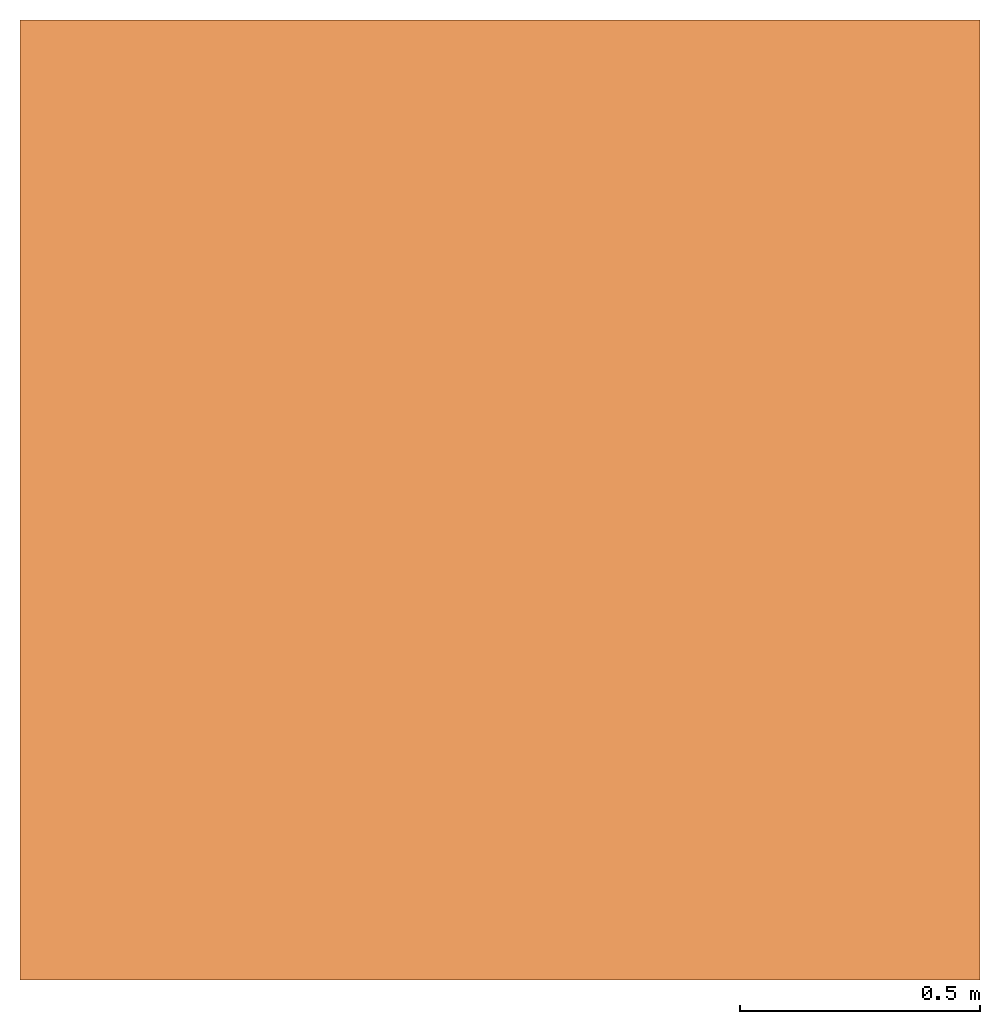
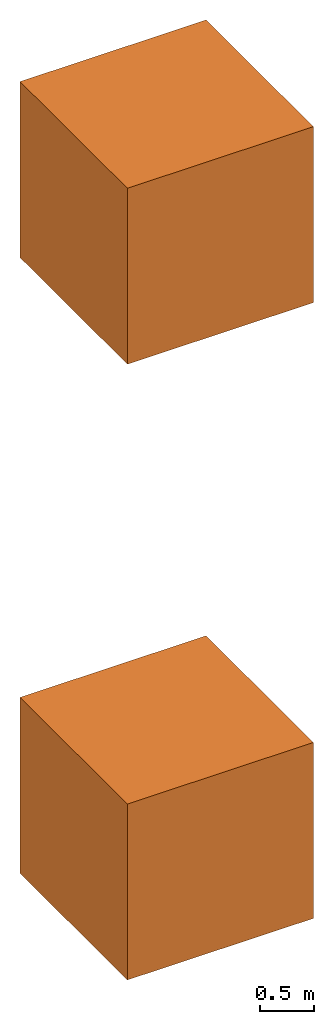
# One storey: 2 built elements.
"""IFC4X3_ADD2 building model written with IfcOpenShell, lengths in metres."""

from ifc_helpers import new_model, entity, si_unit, converted_unit, frame, origin_with_axes, origin_2d_with_axis, place, context, subcontext, project, spatial, polygons, element, save


model = new_model("IFC4X3_ADD2")

# Units and contexts
model_context = context("Model", 3, precision=1e-05, world=origin_with_axes())
plan_context = context("Plan", 2, precision=1e-05, world=origin_2d_with_axis())
body_context = subcontext(model_context, "Body", "Model", "MODEL_VIEW")
ifc_project = project(units=[converted_unit("PLANEANGLEUNIT", "degree", entity("IfcReal", 0.0174532925199433), si_unit("PLANEANGLEUNIT", "RADIAN"), dimensions=[0, 0, 0, 0, 0, 0, 0]), si_unit("AREAUNIT", "SQUARE_METRE"), si_unit("VOLUMEUNIT", "CUBIC_METRE"), si_unit("LENGTHUNIT", "METRE")], contexts=[model_context, plan_context])

# Site, building, storey
site_placement = place(None, origin_with_axes())
site = spatial("IfcSite", under=ifc_project, at=site_placement)
building_placement = place(site_placement, origin_with_axes())
building = spatial("IfcBuilding", under=site, at=building_placement, Name="Building")
storey_placement = place(building_placement, origin_with_axes())
storey = spatial("IfcBuildingStorey", under=building, at=storey_placement, Name="Storey")

# Built elements
for number, where, z_axis, x_axis, name in (
    (1, (0.0, 0.0, 7.0), (0.0, 0.0, 1.0), (1.0, 0.0, 0.0), "Cube"),
    (2, (0.0, 0.0, 0.0), (0.0, 0.0, 1.0), (1.0, 0.0, 0.0), "Cube"),
):
    element("IfcBuiltElement", number, at=place(storey_placement, frame(where, z_axis=z_axis, x_axis=x_axis)), inside=storey, Name=name, context=body_context, shape_type="Tessellation", body=[
        polygons([(-1.0, -1.0, -1.0), (-1.0, -1.0, 1.0), (-1.0, 1.0, -1.0), (-1.0, 1.0, 1.0), (1.0, -1.0, -1.0), (1.0, -1.0, 1.0), (1.0, 1.0, -1.0), (1.0, 1.0, 1.0)], [[[1, 2, 4, 3]], [[3, 4, 8, 7]], [[7, 8, 6, 5]], [[5, 6, 2, 1]], [[3, 7, 5, 1]], [[8, 4, 2, 6]]], closed=True),
    ])

save(model, "model.ifc")
